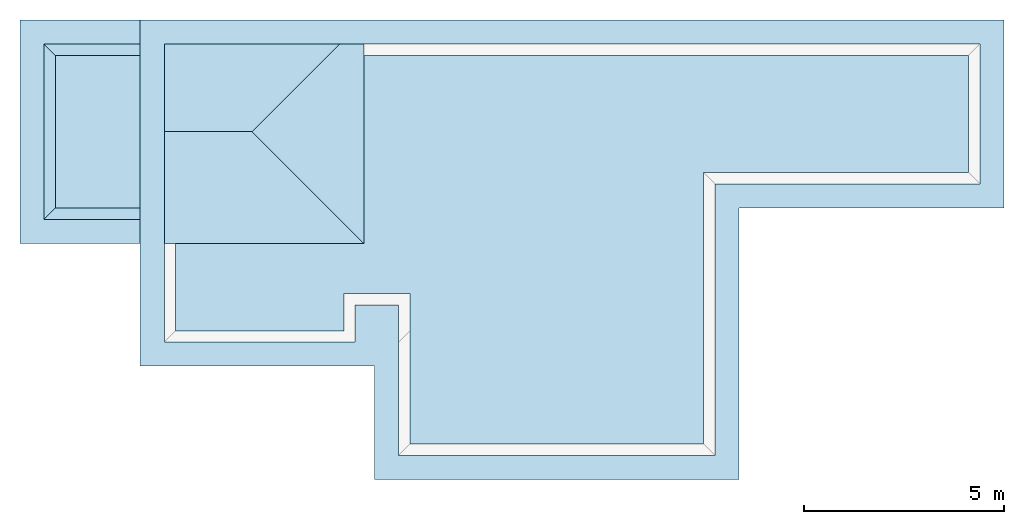
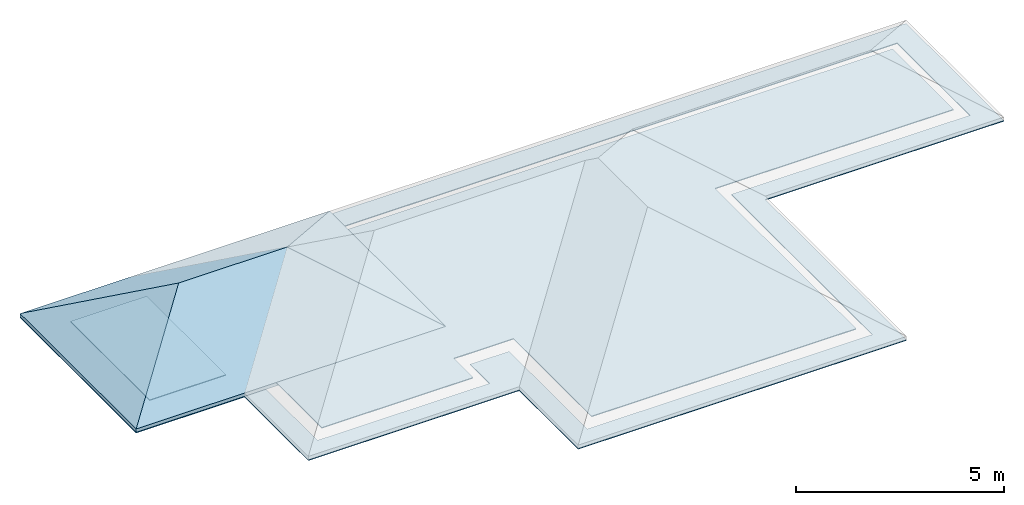
# One storey, part 1 of 2: 4 slabs, 1 roof.
"""IFC4 building model written with IfcOpenShell, lengths in millimetres."""

from ifc_helpers import new_model, entity, si_unit, converted_unit, frame, origin_with_axes, origin_2d_with_axis, place, context, subcontext, project, spatial, line, indexed_curve, outline, extrude, polygons, source, transform, mapped, material, layer, layer_set, layer_usage, type_object, type_shapes, element, save


model = new_model("IFC4")

# Units and contexts
model_context = context("Model", 3, precision=1e-05, world=origin_with_axes())
plan_context = context("Plan", 2, precision=1e-05, world=origin_2d_with_axis())
body_context = subcontext(model_context, "Body", "Model", "MODEL_VIEW")
ifc_project = project(units=[si_unit("VOLUMEUNIT", "CUBIC_METRE"), si_unit("LENGTHUNIT", "METRE", prefix="MILLI"), converted_unit("PLANEANGLEUNIT", "degree", entity("IfcReal", 0.0174532925199433), si_unit("PLANEANGLEUNIT", "RADIAN"), dimensions=[0, 0, 0, 0, 0, 0, 0]), si_unit("AREAUNIT", "SQUARE_METRE")], contexts=[model_context, plan_context])

# Site, building, storey
site_placement = place(None, origin_with_axes())
site = spatial("IfcSite", under=ifc_project, at=site_placement)
building_placement = place(site_placement, origin_with_axes())
building = spatial("IfcBuilding", under=site, at=building_placement, Name="Building")
storey_placement = place(building_placement, origin_with_axes())
storey = spatial("IfcBuildingStorey", under=building, at=storey_placement, Name="Roof")

# Slabs
ifc_material = material()
ifc_layer_1 = layer(ifc_material, 25.0)
ifc_layer_set_1 = layer_set([ifc_layer_1])
ifc_layer_usage_1 = layer_usage(ifc_layer_set_1, "AXIS3", "POSITIVE", 0.0)
slab_type_1 = type_object("IfcSlabType", Name="SOFFIT.25", PredefinedType="NOTDEFINED", material=ifc_layer_set_1)
slab_1_placement = place(storey_placement, frame((-850.880265235901, -2293.33448410034, 2300.00019073486), z_axis=(0.0, 0.0, 1.0), x_axis=(0.999999999999972, 2.38418579101556e-07, 0.0)))
element("IfcSlab", 1, at=slab_1_placement, inside=storey, type_object=slab_type_1, material=ifc_layer_usage_1, Name="Slab", context=body_context, shape_type="SweptSolid", body=[
    extrude(outline(indexed_curve([(0.0, 0.0), (600.000023841858, 0.0), (21555.004119873, 8639.99843597412), (0.0, 8639.99843597412), (600.000023841858, 8039.99900817871), (20955.0018310547, 8039.99900817871), (21555.004119873, 3949.99980926514), (14945.0035095215, 3949.99980926514), (20955.0018310547, 4549.99971389771), (14345.0040817261, 4549.99876022339), (5845.00026702881, -2825.00219345093), (14945.0035095215, -2825.00219345093), (14345.0031280518, -2225.00228881836), (5845.00026702881, 0.0), (6445.00017166138, -2225.00228881836), (6445.00017166138, 1524.99783039093), (5365.00215530396, 1524.99794960022), (5365.00215530396, 599.998831748962), (600.999891757965, 599.998652935028), (600.999891757965, 0.0)], segments=[line(15, 13), line(13, 10), line(10, 9), line(9, 6), line(6, 5), line(5, 2), line(2, 1), line(1, 4), line(4, 3), line(3, 7), line(7, 8), line(8, 12), line(12, 11), line(11, 14), line(14, 20), line(20, 19), line(19, 18), line(18, 17), line(17, 16), line(16, 15)], self_intersect=False)), None, (0.0, 0.0, 1.0), 25.0),
])
ifc_layer_2 = layer(ifc_material, 25.0)
ifc_layer_set_2 = layer_set([ifc_layer_2])
ifc_layer_usage_2 = layer_usage(ifc_layer_set_2, "AXIS3", "POSITIVE", 0.0)
slab_type_2 = type_object("IfcSlabType", Name="10", PredefinedType="NOTDEFINED", material=ifc_layer_set_2)
slab_2_placement = place(storey_placement, frame((34.1202616691589, -1408.331990242, 2400.00009536743), z_axis=(0.0, 0.0, 1.0), x_axis=(0.999999999999972, 2.38418579101556e-07, 0.0)))
element("IfcSlab", 2, at=slab_2_placement, inside=storey, type_object=slab_type_2, material=ifc_layer_usage_2, Name="Slab", context=body_context, shape_type="SweptSolid", body=[
    extrude(outline(indexed_curve([(0.0, 0.0), (4195.00112533569, 0.0), (19785.0017547607, 6869.99893188477), (0.0, 6869.99893188477), (4195.00112533569, 924.99852180481), (19785.0017547607, 3949.99885559082), (13175.0011444092, 3949.99885559082), (5844.99931335449, 924.99828338623), (5844.99883651733, -2825.00171661377), (13175.0001907349, -2825.00195503235)], segments=[line(2, 5), line(5, 8), line(8, 9), line(9, 10), line(10, 7), line(7, 6), line(6, 3), line(3, 4), line(4, 1), line(1, 2)], self_intersect=False)), None, (0.0, 0.0, 1.0), 25.0),
])
ifc_layer_usage_3 = layer_usage(ifc_layer_set_2, "AXIS3", "POSITIVE", 0.0)
slab_3_placement = place(storey_placement, frame((-2965.87824821472, 1656.66604042053, 2400.00009536743), z_axis=(0.0, 0.0, 1.0), x_axis=(1.0, 0.0, 0.0)))
element("IfcSlab", 3, at=slab_3_placement, inside=storey, type_object=slab_type_2, material=ifc_layer_usage_3, Name="Slab", context=body_context, shape_type="SweptSolid", body=[
    extrude(outline(indexed_curve([(0.0, 0.0), (2114.99691009521, 0.0), (2114.99691009521, 3805.00102043152), (0.0, 3805.00102043152)], segments=[line(3, 2), line(2, 1), line(1, 4), line(4, 3)], self_intersect=False)), None, (0.0, 0.0, 1.0), 25.0),
])
ifc_layer_usage_4 = layer_usage(ifc_layer_set_2, "AXIS3", "POSITIVE", 0.0)
slab_4_placement = place(storey_placement, frame((-2965.87800979614, 771.666049957275, 2300.00019073486), z_axis=(0.0, 0.0, 1.0), x_axis=(1.0, 0.0, 0.0)))
element("IfcSlab", 4, at=slab_4_placement, inside=storey, type_object=slab_type_2, material=ifc_layer_usage_4, Name="Slab", context=body_context, shape_type="SweptSolid", body=[
    extrude(outline(indexed_curve([(2114.99691009521, 600.000500679016), (2114.99691009521, 0.0), (-885.001242160797, 0.0), (-885.001242160797, 5574.9979019165), (-285.000205039978, 600.000500679016), (-285.000830888748, 4975.00038146973), (2114.99571800232, 4975.00133514404), (2114.9959564209, 5574.9979019165)], segments=[line(5, 1), line(1, 2), line(2, 3), line(3, 4), line(4, 8), line(8, 7), line(7, 6), line(6, 5)], self_intersect=False)), None, (0.0, 0.0, 1.0), 25.0),
])

# Roof
roof_type = type_object("IfcRoofType", Name="GableEndRoof", PredefinedType="GABLE_ROOF")
shared_shape = source(origin_with_axes(), body_context, "Body", "Tessellation", [
    polygons([(-599.99951171875, -4975.0, -999.999938964844), (7980.89990234375, -4975.0, -999.999938964844), (7980.89990234375, 599.997497558594, -999.999938964844), (-599.99951171875, 599.997497558594, -999.999938964844), (2187.49926757812, -2187.50122070312, 609.36328125), (5193.40087890625, -2187.50122070312, 609.36328125), (-599.99951171875, -4975.0, -899.999938964844), (7980.89990234375, -4975.0, -899.999938964844), (5193.40087890625, -2187.50122070312, 709.36328125), (2187.49926757812, -2187.50122070312, 709.36328125), (-599.99951171875, 599.997497558594, -899.999938964844), (7980.89990234375, 599.997497558594, -899.999938964844)], [[[1, 5, 6, 2]], [[4, 5, 1]], [[3, 6, 5, 4]], [[2, 6, 3]], [[7, 8, 9, 10]], [[11, 7, 10]], [[12, 11, 10, 9]], [[8, 12, 9]], [[3, 4, 11, 12]], [[4, 1, 7, 11]], [[1, 2, 8, 7]], [[2, 3, 12, 8]]], closed=True),
])
type_shapes(roof_type, [shared_shape])
roof_placement = place(storey_placement, frame((-3250.87952613831, 5746.666431427, 3324.00012016296), z_axis=(0.0, 0.0, 1.0), x_axis=(1.0, 0.0, 0.0)))
element("IfcRoof", 5, at=roof_placement, inside=storey, type_object=roof_type, Name="Roof", PredefinedType="HIP_ROOF", context=body_context, shape_type="MappedRepresentation", body=[
    mapped(shared_shape, transform((0.0, 0.0, 0.0), x_axis=(1.0, 0.0, 0.0), y_axis=(0.0, 1.0, 0.0), z_axis=(0.0, 0.0, 1.0), scale=1.0)),
])

save(model, "model.ifc")
